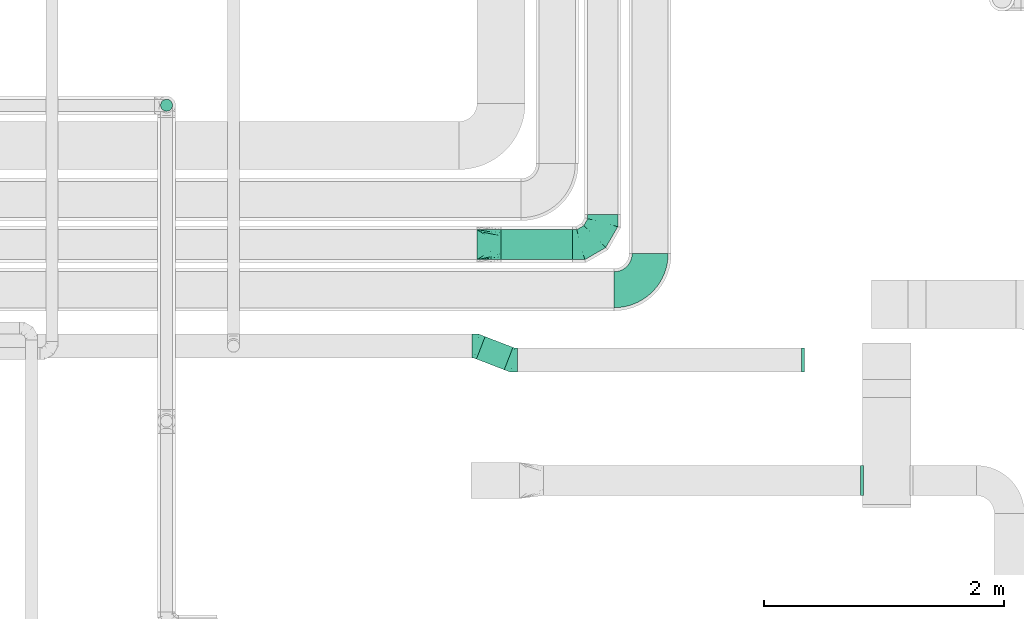
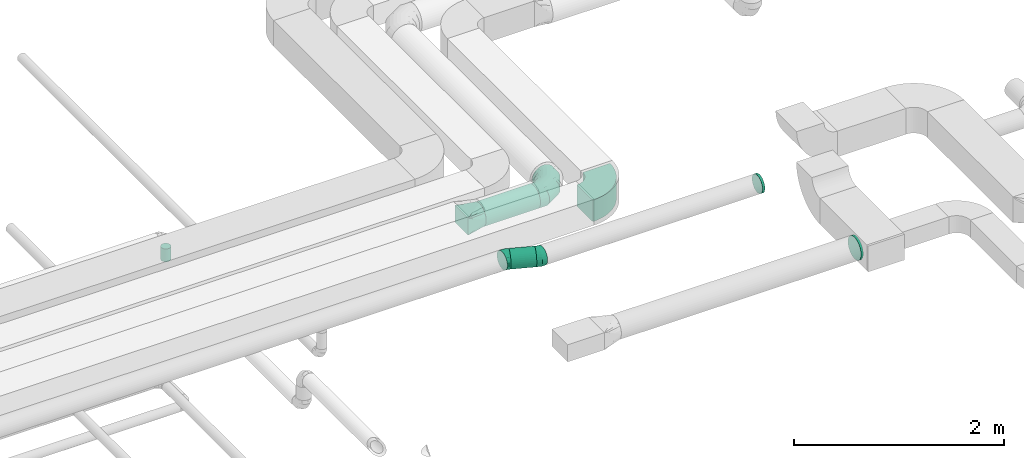
# One storey, part 43 of 92: 7 flow fittings, 3 flow segments.
"""IFC2X3 building model written with IfcOpenShell, lengths in millimetres."""

from ifc_helpers import new_model, entity, si_unit, converted_unit, derived_unit, direction, frame, frame_2d, origin, origin_2d_with_axis, place, context, subcontext, project, spatial, polyline, circle_curve, parameter, trimmed, segment, composite_curve, circle, outline, extrude, faceted_brep, source, transform, mapped, material, type_object, type_shapes, element, save


model = new_model("IFC2X3")

# Units and contexts
model_context = context("Model", 3, precision=0.01, world=origin(), true_north=direction((6.12303176911189e-17, 1.0)))
body_context = subcontext(model_context, "Body", "Model", "MODEL_VIEW")
ifc_project = project(units=[si_unit("LENGTHUNIT", "METRE", prefix="MILLI"), si_unit("AREAUNIT", "SQUARE_METRE"), si_unit("VOLUMEUNIT", "CUBIC_METRE"), converted_unit("PLANEANGLEUNIT", "DEGREE", entity("IfcRatioMeasure", 0.0174532925199433), si_unit("PLANEANGLEUNIT", "RADIAN"), dimensions=[0, 0, 0, 0, 0, 0, 0]), si_unit("MASSUNIT", "GRAM", prefix="KILO"), derived_unit("MASSDENSITYUNIT", [(si_unit("MASSUNIT", "GRAM", prefix="KILO"), 1), (si_unit("LENGTHUNIT", "METRE"), -3)]), derived_unit("MOMENTOFINERTIAUNIT", [(si_unit("LENGTHUNIT", "METRE"), 4)]), si_unit("TIMEUNIT", "SECOND"), si_unit("FREQUENCYUNIT", "HERTZ"), si_unit("THERMODYNAMICTEMPERATUREUNIT", "DEGREE_CELSIUS"), derived_unit("THERMALTRANSMITTANCEUNIT", [(si_unit("MASSUNIT", "GRAM", prefix="KILO"), 1), (si_unit("THERMODYNAMICTEMPERATUREUNIT", "KELVIN"), -1), (si_unit("TIMEUNIT", "SECOND"), -3)]), derived_unit("VOLUMETRICFLOWRATEUNIT", [(si_unit("LENGTHUNIT", "METRE"), 3), (si_unit("TIMEUNIT", "SECOND"), -1)]), derived_unit("MASSFLOWRATEUNIT", [(si_unit("MASSUNIT", "GRAM", prefix="KILO"), 1), (si_unit("TIMEUNIT", "SECOND"), -1)]), derived_unit("ROTATIONALFREQUENCYUNIT", [(si_unit("TIMEUNIT", "SECOND"), -1)]), si_unit("ELECTRICCURRENTUNIT", "AMPERE"), si_unit("ELECTRICVOLTAGEUNIT", "VOLT"), si_unit("POWERUNIT", "WATT"), si_unit("FORCEUNIT", "NEWTON", prefix="KILO"), si_unit("ILLUMINANCEUNIT", "LUX"), si_unit("LUMINOUSFLUXUNIT", "LUMEN"), si_unit("LUMINOUSINTENSITYUNIT", "CANDELA"), derived_unit("USERDEFINED", [(si_unit("MASSUNIT", "GRAM", prefix="KILO"), -1), (si_unit("LENGTHUNIT", "METRE"), -2), (si_unit("TIMEUNIT", "SECOND"), 3), (si_unit("LUMINOUSFLUXUNIT", "LUMEN"), 1)]), derived_unit("LINEARVELOCITYUNIT", [(si_unit("LENGTHUNIT", "METRE"), 1), (si_unit("TIMEUNIT", "SECOND"), -1)]), si_unit("PRESSUREUNIT", "PASCAL"), derived_unit("USERDEFINED", [(si_unit("LENGTHUNIT", "METRE"), -2), (si_unit("MASSUNIT", "GRAM", prefix="KILO"), 1), (si_unit("TIMEUNIT", "SECOND"), -2)]), derived_unit("LINEARFORCEUNIT", [(si_unit("MASSUNIT", "GRAM", prefix="KILO"), 1), (si_unit("LENGTHUNIT", "METRE"), 1), (si_unit("TIMEUNIT", "SECOND"), -2), (si_unit("LENGTHUNIT", "METRE"), -1)]), derived_unit("PLANARFORCEUNIT", [(si_unit("MASSUNIT", "GRAM", prefix="KILO"), 1), (si_unit("LENGTHUNIT", "METRE"), 1), (si_unit("TIMEUNIT", "SECOND"), -2), (si_unit("LENGTHUNIT", "METRE"), -2)])], contexts=[model_context])

# Site, building, storey
site_placement = place(None, origin())
site = spatial("IfcSite", under=ifc_project, at=site_placement, CompositionType="ELEMENT")
building_placement = place(site_placement, origin())
building = spatial("IfcBuilding", under=site, at=building_placement, CompositionType="ELEMENT")
storey_placement = place(building_placement, frame((0.0, 0.0, 4200.0)))
storey = spatial("IfcBuildingStorey", under=building, at=storey_placement, CompositionType="ELEMENT", Elevation=4200.0)

# Flow segments
duct_segment_type = type_object("IfcDuctSegmentType", PredefinedType="NOTDEFINED")
flow_segment_1_placement = place(storey_placement, frame((21724.05, 12068.05, 3173.4)))
element("IfcFlowSegment", 1, at=flow_segment_1_placement, inside=storey, type_object=duct_segment_type, context=body_context, shape_type="SweptSolid", body=[
    extrude(circle(Radius=125.0, at=origin_2d_with_axis()), frame((0.0, 126.6, 126.6), z_axis=(1.0, 0.0, 0.0), x_axis=(0.0, -1.0, 0.0)), (0.0, 0.0, 1.0), 596.921497590628),
])
flow_segment_2_placement = place(storey_placement, frame((18890.46, 13302.68, 3050.0)))
element("IfcFlowSegment", 2, at=flow_segment_2_placement, inside=storey, type_object=duct_segment_type, context=body_context, shape_type="SweptSolid", body=[
    extrude(circle(Radius=50.0, at=origin_2d_with_axis()), frame((51.6, 51.6, 0.0), z_axis=(0.0, 0.0, 1.0), x_axis=(0.0, 1.0, 0.0)), (0.0, 0.0, 1.0), 150.000000000007),
])
flow_segment_3_placement = place(storey_placement, frame((21518.46, 11152.26, 3258.4)))
element("IfcFlowSegment", 3, at=flow_segment_3_placement, inside=storey, type_object=duct_segment_type, context=body_context, shape_type="SweptSolid", body=[
    extrude(circle(Radius=100.0, at=origin_2d_with_axis()), frame((37.63, 184.28, 101.6), z_axis=(0.93280621162053, -0.360378372772499, 0.0), x_axis=(-0.360378372772499, -0.93280621162053, 0.0)), (0.0, 0.0, 1.0), 248.086941829669),
])

# Flow fittings
ifc_material = material()
duct_fitting_type_1 = type_object("IfcDuctFittingType", PredefinedType="NOTDEFINED", material=ifc_material)
shared_shape_1 = source(origin(), body_context, "Body", "Brep", [
    faceted_brep([(-250.0, 0.0, -125.0), (-250.0, -32.35, -120.74), (-250.0, -62.5, -108.25), (-250.0, -88.39, -88.39), (-250.0, -108.25, -62.5), (-250.0, -120.74, -32.35), (-250.0, -125.0, 0.0), (-250.0, -120.74, 32.35), (-250.0, -108.25, 62.5), (-250.0, -88.39, 88.39), (-250.0, -62.5, 108.25), (-250.0, -32.35, 120.74), (-250.0, 0.0, 125.0), (-250.0, 32.35, 120.74), (-250.0, 62.5, 108.25), (-250.0, 88.39, 88.39), (-250.0, 108.25, 62.5), (-250.0, 120.74, 32.35), (-250.0, 125.0, 0.0), (-250.0, 120.74, -32.35), (-250.0, 108.25, -62.5), (-250.0, 88.39, -88.39), (-250.0, 62.5, -108.25), (-250.0, 32.35, -120.74), (-191.68, 32.35, 120.74), (-199.76, 62.5, 108.25), (-183.01, 0.0, 125.0), (-206.7, 88.39, 88.39), (-215.37, 120.74, 32.35), (-216.51, 125.0, 0.0), (-212.02, 108.25, 62.5), (-212.02, 108.25, -62.5), (-206.7, 88.39, -88.39), (-215.37, 120.74, -32.35), (-191.68, 32.35, -120.74), (-183.01, 0.0, -125.0), (-199.76, 62.5, -108.25), (-174.34, -32.35, -120.74), (-166.27, -62.5, -108.25), (-159.33, -88.39, -88.39), (-154.01, -108.25, -62.5), (-150.66, -120.74, -32.35), (-149.52, -125.0, 0.0), (-150.66, -120.74, 32.35), (-154.01, -108.25, 62.5), (-159.33, -88.39, 88.39), (-166.27, -62.5, 108.25), (-174.34, -32.35, 120.74), (-90.67, 90.67, 120.74), (-112.74, 112.74, 108.25), (-66.99, 66.99, 125.0), (-131.69, 131.69, 88.39), (-146.23, 146.23, 62.5), (-155.38, 155.38, 32.35), (-158.49, 158.49, 0.0), (-155.38, 155.38, -32.35), (-146.23, 146.23, -62.5), (-131.69, 131.69, -88.39), (-90.67, 90.67, -120.74), (-66.99, 66.99, -125.0), (-112.74, 112.74, -108.25), (-43.3, 43.3, -120.74), (-21.23, 21.23, -108.25), (-2.28, 2.28, -88.39), (12.26, -12.26, -62.5), (21.4, -21.4, -32.35), (24.52, -24.52, 0.0), (21.4, -21.4, 32.35), (12.26, -12.26, 62.5), (-2.28, 2.28, 88.39), (-21.23, 21.23, 108.25), (-43.3, 43.3, 120.74), (-32.35, 191.68, 120.74), (-62.5, 199.76, 108.25), (0.0, 183.01, 125.0), (-88.39, 206.7, 88.39), (-108.25, 212.02, 62.5), (-120.74, 215.37, 32.35), (-125.0, 216.51, 0.0), (-120.74, 215.37, -32.35), (-108.25, 212.02, -62.5), (-88.39, 206.7, -88.39), (-32.35, 191.68, -120.74), (0.0, 183.01, -125.0), (-62.5, 199.76, -108.25), (32.35, 174.34, -120.74), (62.5, 166.27, -108.25), (88.39, 159.33, -88.39), (108.25, 154.01, -62.5), (120.74, 150.66, -32.35), (125.0, 149.52, 0.0), (120.74, 150.66, 32.35), (108.25, 154.01, 62.5), (88.39, 159.33, 88.39), (62.5, 166.27, 108.25), (32.35, 174.34, 120.74), (-32.35, 250.0, -120.74), (-62.5, 250.0, -108.25), (-88.39, 250.0, -88.39), (-108.25, 250.0, -62.5), (-120.74, 250.0, -32.35), (-125.0, 250.0, 0.0), (-120.74, 250.0, 32.35), (-108.25, 250.0, 62.5), (-88.39, 250.0, 88.39), (-62.5, 250.0, 108.25), (-32.35, 250.0, 120.74), (0.0, 250.0, 125.0), (32.35, 250.0, 120.74), (62.5, 250.0, 108.25), (88.39, 250.0, 88.39), (108.25, 250.0, 62.5), (120.74, 250.0, 32.35), (125.0, 250.0, 0.0), (120.74, 250.0, -32.35), (108.25, 250.0, -62.5), (88.39, 250.0, -88.39), (62.5, 250.0, -108.25), (32.35, 250.0, -120.74), (0.0, 250.0, -125.0)], [[[0, 1, 2, 3, 4, 5, 6, 7, 8, 9, 10, 11, 12, 13, 14, 15, 16, 17, 18, 19, 20, 21, 22, 23]], [[24, 25, 14, 13]], [[26, 24, 13, 12]], [[14, 25, 27, 15]], [[28, 29, 18, 17]], [[30, 28, 17, 16]], [[15, 27, 30, 16]], [[20, 31, 32, 21]], [[33, 31, 20, 19]], [[18, 29, 33, 19]], [[34, 35, 0, 23]], [[36, 34, 23, 22]], [[21, 32, 36, 22]], [[1, 0, 35, 37]], [[2, 1, 37, 38]], [[38, 39, 3, 2]], [[5, 4, 40, 41]], [[6, 5, 41, 42]], [[39, 40, 4, 3]], [[6, 42, 43, 7]], [[7, 43, 44, 8]], [[8, 44, 45, 9]], [[9, 45, 46, 10]], [[10, 46, 47, 11]], [[26, 12, 11, 47]], [[48, 49, 25, 24]], [[50, 48, 24, 26]], [[27, 25, 49, 51]], [[52, 53, 28, 30]], [[51, 52, 30, 27]], [[29, 28, 53, 54]], [[55, 56, 31, 33]], [[54, 55, 33, 29]], [[32, 31, 56, 57]], [[58, 59, 35, 34]], [[60, 58, 34, 36]], [[57, 60, 36, 32]], [[37, 35, 59, 61]], [[38, 37, 61, 62]], [[39, 38, 62, 63]], [[41, 40, 64, 65]], [[42, 41, 65, 66]], [[63, 64, 40, 39]], [[43, 42, 66, 67]], [[44, 43, 67, 68]], [[68, 69, 45, 44]], [[46, 45, 69, 70]], [[47, 46, 70, 71]], [[26, 47, 71, 50]], [[72, 73, 49, 48]], [[74, 72, 48, 50]], [[51, 49, 73, 75]], [[76, 77, 53, 52]], [[75, 76, 52, 51]], [[54, 53, 77, 78]], [[79, 80, 56, 55]], [[78, 79, 55, 54]], [[57, 56, 80, 81]], [[82, 83, 59, 58]], [[84, 82, 58, 60]], [[81, 84, 60, 57]], [[61, 59, 83, 85]], [[62, 61, 85, 86]], [[63, 62, 86, 87]], [[65, 64, 88, 89]], [[66, 65, 89, 90]], [[87, 88, 64, 63]], [[67, 66, 90, 91]], [[68, 67, 91, 92]], [[92, 93, 69, 68]], [[70, 69, 93, 94]], [[71, 70, 94, 95]], [[50, 71, 95, 74]], [[96, 97, 98, 99, 100, 101, 102, 103, 104, 105, 106, 107, 108, 109, 110, 111, 112, 113, 114, 115, 116, 117, 118, 119]], [[72, 74, 107, 106]], [[73, 72, 106, 105]], [[75, 73, 105, 104]], [[77, 76, 103, 102]], [[78, 77, 102, 101]], [[75, 104, 103, 76]], [[78, 101, 100, 79]], [[79, 100, 99, 80]], [[80, 99, 98, 81]], [[84, 97, 96, 82]], [[82, 96, 119, 83]], [[84, 81, 98, 97]], [[83, 119, 118, 85]], [[85, 118, 117, 86]], [[116, 87, 86, 117]], [[88, 115, 114, 89]], [[89, 114, 113, 90]], [[115, 88, 87, 116]], [[91, 90, 113, 112]], [[92, 91, 112, 111]], [[111, 110, 93, 92]], [[95, 94, 109, 108]], [[74, 95, 108, 107]], [[110, 109, 94, 93]]]),
])
type_shapes(duct_fitting_type_1, [shared_shape_1])
flow_fitting_1_placement = place(storey_placement, frame((22570.98, 12194.64, 3300.0)))
element("IfcFlowFitting", 4, at=flow_fitting_1_placement, inside=storey, type_object=duct_fitting_type_1, material=ifc_material, context=body_context, shape_type="MappedRepresentation", body=[
    mapped(shared_shape_1, transform((0.0, 0.0, 0.0), scale=1.0)),
])
duct_fitting_type_2 = type_object("IfcDuctFittingType", PredefinedType="NOTDEFINED", material=ifc_material)
shared_shape_2 = source(origin(), body_context, "Body", "Brep", [
    faceted_brep([(20.0, 32.35, -120.74), (20.0, 62.5, -108.25), (20.0, 88.39, -88.39), (20.0, 108.25, -62.5), (20.0, 120.74, -32.35), (20.0, 125.0, 0.0), (20.0, 120.74, 32.35), (20.0, 108.25, 62.5), (20.0, 88.39, 88.39), (20.0, 62.5, 108.25), (20.0, 32.35, 120.74), (20.0, 0.0, 125.0), (20.0, -32.35, 120.74), (20.0, -62.5, 108.25), (20.0, -88.39, 88.39), (20.0, -108.25, 62.5), (20.0, -120.74, 32.35), (20.0, -125.0, 0.0), (20.0, -120.74, -32.35), (20.0, -108.25, -62.5), (20.0, -88.39, -88.39), (20.0, -62.5, -108.25), (20.0, -32.35, -120.74), (20.0, 0.0, -125.0), (0.0, 0.0, 125.0), (0.0, 32.35, 120.74), (-6.1, 32.35, 120.74), (-6.1, 0.0, 125.0), (0.0, 62.5, 108.25), (-6.1, 62.5, 108.25), (0.0, 88.39, 88.39), (-6.1, 88.39, 88.39), (0.0, 108.25, 62.5), (0.0, 120.74, 32.35), (-6.1, 120.74, 32.35), (-6.1, 108.25, 62.5), (0.0, 125.0, 0.0), (-6.1, 125.0, 0.0), (0.0, 120.74, -32.35), (-6.1, 120.74, -32.35), (0.0, 108.25, -62.5), (-6.1, 108.25, -62.5), (0.0, 88.39, -88.39), (-6.1, 88.39, -88.39), (0.0, 62.5, -108.25), (0.0, 32.35, -120.74), (-6.1, 32.35, -120.74), (-6.1, 62.5, -108.25), (0.0, 0.0, -125.0), (-6.1, 0.0, -125.0), (0.0, -32.35, -120.74), (-6.1, -32.35, -120.74), (0.0, -62.5, -108.25), (-6.1, -62.5, -108.25), (0.0, -88.39, -88.39), (-6.1, -88.39, -88.39), (0.0, -108.25, -62.5), (0.0, -120.74, -32.35), (-6.1, -120.74, -32.35), (-6.1, -108.25, -62.5), (0.0, -125.0, 0.0), (-6.1, -125.0, 0.0), (0.0, -120.74, 32.35), (-6.1, -120.74, 32.35), (0.0, -108.25, 62.5), (-6.1, -108.25, 62.5), (0.0, -88.39, 88.39), (-6.1, -88.39, 88.39), (0.0, -62.5, 108.25), (0.0, -32.35, 120.74), (-6.1, -32.35, 120.74), (-6.1, -62.5, 108.25)], [[[0, 1, 2, 3, 4, 5, 6, 7, 8, 9, 10, 11, 12, 13, 14, 15, 16, 17, 18, 19, 20, 21, 22, 23]], [[24, 11, 10, 25, 26, 27]], [[25, 10, 9, 28, 29, 26]], [[28, 9, 8, 30, 31, 29]], [[32, 7, 6, 33, 34, 35]], [[33, 6, 5, 36, 37, 34]], [[30, 8, 7, 32, 35, 31]], [[36, 5, 4, 38, 39, 37]], [[38, 4, 3, 40, 41, 39]], [[40, 3, 2, 42, 43, 41]], [[44, 1, 0, 45, 46, 47]], [[45, 0, 23, 48, 49, 46]], [[42, 2, 1, 44, 47, 43]], [[48, 23, 22, 50, 51, 49]], [[50, 22, 21, 52, 53, 51]], [[52, 21, 20, 54, 55, 53]], [[56, 19, 18, 57, 58, 59]], [[57, 18, 17, 60, 61, 58]], [[54, 20, 19, 56, 59, 55]], [[60, 17, 16, 62, 63, 61]], [[62, 16, 15, 64, 65, 63]], [[64, 15, 14, 66, 67, 65]], [[68, 13, 12, 69, 70, 71]], [[69, 12, 11, 24, 27, 70]], [[66, 14, 13, 68, 71, 67]], [[49, 51, 53, 55, 59, 58, 61, 63, 65, 67, 71, 70, 27, 26, 29, 31, 35, 34, 37, 39, 41, 43, 47, 46]]]),
])
type_shapes(duct_fitting_type_2, [shared_shape_2])
flow_fitting_2_placement = place(storey_placement, frame((24733.23, 10232.66, 3050.0), z_axis=(0.0, 0.0, -1.0), x_axis=(-1.0, 0.0, 0.0)))
element("IfcFlowFitting", 5, at=flow_fitting_2_placement, inside=storey, type_object=duct_fitting_type_2, material=ifc_material, context=body_context, shape_type="MappedRepresentation", body=[
    mapped(shared_shape_2, transform((0.0, 0.0, 0.0), scale=1.0)),
])
duct_fitting_type_3 = type_object("IfcDuctFittingType", PredefinedType="NOTDEFINED", material=ifc_material)
shared_shape_3 = source(origin(), body_context, "Body", "Brep", [
    faceted_brep([(20.0, 25.88, -96.59), (20.0, 50.0, -86.6), (20.0, 70.71, -70.71), (20.0, 86.6, -50.0), (20.0, 96.59, -25.88), (20.0, 100.0, 0.0), (20.0, 96.59, 25.88), (20.0, 86.6, 50.0), (20.0, 70.71, 70.71), (20.0, 50.0, 86.6), (20.0, 25.88, 96.59), (20.0, 0.0, 100.0), (20.0, -25.88, 96.59), (20.0, -50.0, 86.6), (20.0, -70.71, 70.71), (20.0, -86.6, 50.0), (20.0, -96.59, 25.88), (20.0, -100.0, 0.0), (20.0, -96.59, -25.88), (20.0, -86.6, -50.0), (20.0, -70.71, -70.71), (20.0, -50.0, -86.6), (20.0, -25.88, -96.59), (20.0, 0.0, -100.0), (0.0, 0.0, 100.0), (0.0, 25.88, 96.59), (-6.1, 25.88, 96.59), (-6.1, 0.0, 100.0), (0.0, 50.0, 86.6), (-6.1, 50.0, 86.6), (0.0, 70.71, 70.71), (-6.1, 70.71, 70.71), (0.0, 86.6, 50.0), (0.0, 96.59, 25.88), (-6.1, 96.59, 25.88), (-6.1, 86.6, 50.0), (0.0, 100.0, 0.0), (-6.1, 100.0, 0.0), (0.0, 96.59, -25.88), (-6.1, 96.59, -25.88), (0.0, 86.6, -50.0), (-6.1, 86.6, -50.0), (0.0, 70.71, -70.71), (-6.1, 70.71, -70.71), (0.0, 50.0, -86.6), (0.0, 25.88, -96.59), (-6.1, 25.88, -96.59), (-6.1, 50.0, -86.6), (0.0, 0.0, -100.0), (-6.1, 0.0, -100.0), (0.0, -25.88, -96.59), (-6.1, -25.88, -96.59), (0.0, -50.0, -86.6), (-6.1, -50.0, -86.6), (0.0, -70.71, -70.71), (-6.1, -70.71, -70.71), (0.0, -86.6, -50.0), (0.0, -96.59, -25.88), (-6.1, -96.59, -25.88), (-6.1, -86.6, -50.0), (0.0, -100.0, 0.0), (-6.1, -100.0, 0.0), (0.0, -96.59, 25.88), (-6.1, -96.59, 25.88), (0.0, -86.6, 50.0), (-6.1, -86.6, 50.0), (0.0, -70.71, 70.71), (-6.1, -70.71, 70.71), (0.0, -50.0, 86.6), (0.0, -25.88, 96.59), (-6.1, -25.88, 96.59), (-6.1, -50.0, 86.6)], [[[0, 1, 2, 3, 4, 5, 6, 7, 8, 9, 10, 11, 12, 13, 14, 15, 16, 17, 18, 19, 20, 21, 22, 23]], [[24, 11, 10, 25, 26, 27]], [[25, 10, 9, 28, 29, 26]], [[28, 9, 8, 30, 31, 29]], [[32, 7, 6, 33, 34, 35]], [[33, 6, 5, 36, 37, 34]], [[30, 8, 7, 32, 35, 31]], [[36, 5, 4, 38, 39, 37]], [[38, 4, 3, 40, 41, 39]], [[40, 3, 2, 42, 43, 41]], [[44, 1, 0, 45, 46, 47]], [[45, 0, 23, 48, 49, 46]], [[42, 2, 1, 44, 47, 43]], [[48, 23, 22, 50, 51, 49]], [[50, 22, 21, 52, 53, 51]], [[52, 21, 20, 54, 55, 53]], [[56, 19, 18, 57, 58, 59]], [[57, 18, 17, 60, 61, 58]], [[54, 20, 19, 56, 59, 55]], [[60, 17, 16, 62, 63, 61]], [[62, 16, 15, 64, 65, 63]], [[64, 15, 14, 66, 67, 65]], [[68, 13, 12, 69, 70, 71]], [[69, 12, 11, 24, 27, 70]], [[66, 14, 13, 68, 71, 67]], [[49, 51, 53, 55, 59, 58, 61, 63, 65, 67, 71, 70, 27, 26, 29, 31, 35, 34, 37, 39, 41, 43, 47, 46]]]),
])
type_shapes(duct_fitting_type_3, [shared_shape_3])
flow_fitting_3_placement = place(storey_placement, frame((24242.3, 11233.69, 3360.0), z_axis=(0.0, 1.0, 0.0), x_axis=(-1.0, 0.0, 0.0)))
element("IfcFlowFitting", 6, at=flow_fitting_3_placement, inside=storey, type_object=duct_fitting_type_3, material=ifc_material, context=body_context, shape_type="MappedRepresentation", body=[
    mapped(shared_shape_3, transform((0.0, 0.0, 0.0), scale=1.0)),
])
duct_fitting_type_4 = type_object("IfcDuctFittingType", PredefinedType="NOTDEFINED", material=ifc_material)
shared_shape_4 = source(origin(), body_context, "Body", "Brep", [
    faceted_brep([(200.0, 73.47, 101.13), (200.0, 56.05, 110.0), (200.0, 38.63, 118.88), (200.0, 23.84, 121.22), (200.0, 11.92, 123.11), (200.0, 5.96, 124.06), (200.0, 0.0, 125.0), (200.0, -5.96, 124.06), (200.0, -11.92, 123.11), (200.0, -23.84, 121.22), (200.0, -38.63, 118.88), (200.0, -56.05, 110.0), (200.0, -73.47, 101.13), (200.0, -87.3, 87.3), (200.0, -101.13, 73.47), (200.0, -110.0, 56.05), (200.0, -118.88, 38.63), (200.0, -121.22, 23.84), (200.0, -123.11, 11.92), (200.0, -124.06, 5.96), (200.0, -125.0, 0.0), (200.0, -124.06, -5.96), (200.0, -123.11, -11.92), (200.0, -121.22, -23.84), (200.0, -118.88, -38.63), (200.0, -110.0, -56.05), (200.0, -101.13, -73.47), (200.0, -87.3, -87.3), (200.0, -73.47, -101.13), (200.0, -56.05, -110.0), (200.0, -38.63, -118.88), (200.0, -23.84, -121.22), (200.0, -11.92, -123.11), (200.0, -5.96, -124.06), (200.0, 0.0, -125.0), (200.0, 5.96, -124.06), (200.0, 11.92, -123.11), (200.0, 23.84, -121.22), (200.0, 38.63, -118.88), (200.0, 56.05, -110.0), (200.0, 73.47, -101.13), (200.0, 87.3, -87.3), (200.0, 101.13, -73.47), (200.0, 110.0, -56.05), (200.0, 118.88, -38.63), (200.0, 121.22, -23.84), (200.0, 123.11, -11.92), (200.0, 124.06, -5.96), (200.0, 125.0, 0.0), (200.0, 124.06, 5.96), (200.0, 123.11, 11.92), (200.0, 121.22, 23.84), (200.0, 118.88, 38.63), (200.0, 110.0, 56.05), (200.0, 101.13, 73.47), (200.0, 87.3, 87.3), (0.0, -125.0, 100.0), (0.0, 125.0, 100.0), (0.0, 125.0, -100.0), (0.0, -125.0, -100.0), (104.11, -59.93, 113.01), (100.0, -103.94, 96.79), (26.03, -108.73, 103.25), (78.09, -76.2, 109.76), (52.06, -92.46, 106.51), (188.01, -7.49, 123.5), (176.03, -14.98, 122.0), (152.06, -29.96, 119.01), (128.09, -44.95, 116.01), (52.06, -125.0, 73.97), (78.09, -125.0, 60.96), (104.11, -125.0, 47.94), (128.09, -125.0, 35.96), (152.06, -125.0, 23.97), (176.03, -125.0, 11.99), (188.01, -125.0, 5.99), (26.03, -125.0, 86.99), (26.03, -125.0, -86.99), (52.06, -125.0, -73.97), (78.09, -125.0, -60.96), (104.11, -125.0, -47.94), (128.09, -125.0, -35.96), (152.06, -125.0, -23.97), (176.03, -125.0, -11.99), (188.01, -125.0, -5.99), (100.0, -109.29, -91.44), (52.06, -92.46, -106.51), (78.09, -76.2, -109.76), (104.11, -59.93, -113.01), (128.09, -44.95, -116.01), (152.06, -29.96, -119.01), (176.03, -14.98, -122.0), (188.01, -7.49, -123.5), (26.03, -108.73, -103.25), (26.03, 108.73, -103.25), (52.06, 92.46, -106.51), (78.09, 76.2, -109.76), (104.11, 59.93, -113.01), (128.09, 44.95, -116.01), (152.06, 29.96, -119.01), (176.03, 14.98, -122.0), (188.01, 7.49, -123.5), (100.0, 103.94, -96.79), (52.06, 125.0, -73.97), (78.09, 125.0, -60.96), (104.11, 125.0, -47.94), (128.09, 125.0, -35.96), (152.06, 125.0, -23.97), (176.03, 125.0, -11.99), (188.01, 125.0, -5.99), (26.03, 125.0, -86.99), (26.03, 125.0, 86.99), (52.06, 125.0, 73.97), (78.09, 125.0, 60.96), (104.11, 125.0, 47.94), (128.09, 125.0, 35.96), (152.06, 125.0, 23.97), (176.03, 125.0, 11.99), (188.01, 125.0, 5.99), (100.0, 109.29, 91.44), (52.06, 92.46, 106.51), (78.09, 76.2, 109.76), (104.11, 59.93, 113.01), (128.09, 44.95, 116.01), (152.06, 29.96, 119.01), (176.03, 14.98, 122.0), (188.01, 7.49, 123.5), (26.03, 108.73, 103.25)], [[[0, 1, 2, 3, 4, 5, 6, 7, 8, 9, 10, 11, 12, 13, 14, 15, 16, 17, 18, 19, 20, 21, 22, 23, 24, 25, 26, 27, 28, 29, 30, 31, 32, 33, 34, 35, 36, 37, 38, 39, 40, 41, 42, 43, 44, 45, 46, 47, 48, 49, 50, 51, 52, 53, 54, 55]], [[56, 57, 58, 59]], [[60, 11, 10]], [[56, 61, 62]], [[11, 60, 63, 64]], [[65, 66, 67, 68, 60, 10, 9, 8, 7, 6]], [[62, 61, 12]], [[15, 69, 70, 71]], [[64, 12, 11]], [[16, 71, 72, 73, 74, 75, 20, 19, 18, 17]], [[14, 76, 69]], [[71, 16, 15]], [[61, 76, 13]], [[12, 64, 62]], [[76, 14, 13]], [[12, 61, 13]], [[61, 56, 76]], [[69, 15, 14]], [[75, 74, 73, 72, 71, 70, 69, 76, 56, 59, 77, 78, 79, 80, 81, 82, 83, 84, 20]], [[80, 25, 24]], [[59, 85, 77]], [[25, 80, 79, 78]], [[84, 83, 82, 81, 80, 24, 23, 22, 21, 20]], [[77, 85, 26]], [[29, 86, 87, 88]], [[78, 26, 25]], [[30, 88, 89, 90, 91, 92, 34, 33, 32, 31]], [[28, 93, 86]], [[88, 30, 29]], [[85, 93, 27]], [[26, 78, 77]], [[93, 28, 27]], [[26, 85, 27]], [[85, 59, 93]], [[86, 29, 28]], [[92, 91, 90, 89, 88, 87, 86, 93, 59, 58, 94, 95, 96, 97, 98, 99, 100, 101, 34]], [[97, 39, 38]], [[58, 102, 94]], [[39, 97, 96, 95]], [[101, 100, 99, 98, 97, 38, 37, 36, 35, 34]], [[94, 102, 40]], [[43, 103, 104, 105]], [[95, 40, 39]], [[44, 105, 106, 107, 108, 109, 48, 47, 46, 45]], [[42, 110, 103]], [[105, 44, 43]], [[102, 110, 41]], [[40, 95, 94]], [[110, 42, 41]], [[40, 102, 41]], [[102, 58, 110]], [[103, 43, 42]], [[58, 57, 111, 112, 113, 114, 115, 116, 117, 118, 48, 109, 108, 107, 106, 105, 104, 103, 110]], [[114, 53, 52]], [[57, 119, 111]], [[53, 114, 113, 112]], [[118, 117, 116, 115, 114, 52, 51, 50, 49, 48]], [[111, 119, 54]], [[1, 120, 121, 122]], [[112, 54, 53]], [[2, 122, 123, 124, 125, 126, 6, 5, 4, 3]], [[0, 127, 120]], [[122, 2, 1]], [[119, 127, 55]], [[54, 112, 111]], [[127, 0, 55]], [[54, 119, 55]], [[119, 57, 127]], [[120, 1, 0]], [[57, 56, 62, 64, 63, 60, 68, 67, 66, 65, 6, 126, 125, 124, 123, 122, 121, 120, 127]]]),
])
type_shapes(duct_fitting_type_4, [shared_shape_4])
flow_fitting_4_placement = place(storey_placement, frame((21524.05, 12194.64, 3300.0)))
element("IfcFlowFitting", 7, at=flow_fitting_4_placement, inside=storey, type_object=duct_fitting_type_4, material=ifc_material, context=body_context, shape_type="MappedRepresentation", body=[
    mapped(shared_shape_4, transform((0.0, 0.0, 0.0), scale=1.0)),
])
duct_fitting_type_5 = type_object("IfcDuctFittingType", PredefinedType="NOTDEFINED", material=ifc_material)
shared_shape_5 = source(origin(), body_context, "Body", "Brep", [
    faceted_brep([(-37.29, 0.0, -100.0), (-37.29, -25.88, -96.59), (-37.29, -50.0, -86.6), (-37.29, -70.71, -70.71), (-37.29, -86.6, -50.0), (-37.29, -96.59, -25.88), (-37.29, -100.0, 0.0), (-37.29, -96.59, 25.88), (-37.29, -86.6, 50.0), (-37.29, -70.71, 70.71), (-37.29, -50.0, 86.6), (-37.29, -25.88, 96.59), (-37.29, 0.0, 100.0), (-37.29, 25.88, 96.59), (-37.29, 50.0, 86.6), (-37.29, 70.71, 70.71), (-37.29, 86.6, 50.0), (-37.29, 96.59, 25.88), (-37.29, 100.0, 0.0), (-37.29, 96.59, -25.88), (-37.29, 86.6, -50.0), (-37.29, 70.71, -70.71), (-37.29, 50.0, -86.6), (-37.29, 25.88, -96.59), (-4.83, 25.88, 96.59), (-9.32, 50.0, 86.6), (0.0, 0.0, 100.0), (-13.18, 70.71, 70.71), (-18.01, 96.59, 25.88), (-18.65, 100.0, 0.0), (-16.15, 86.6, 50.0), (-16.15, 86.6, -50.0), (-13.18, 70.71, -70.71), (-18.01, 96.59, -25.88), (-4.83, 25.88, -96.59), (0.0, 0.0, -100.0), (-9.32, 50.0, -86.6), (4.83, -25.88, -96.59), (9.32, -50.0, -86.6), (13.18, -70.71, -70.71), (16.15, -86.6, -50.0), (18.01, -96.59, -25.88), (18.65, -100.0, 0.0), (18.01, -96.59, 25.88), (16.15, -86.6, 50.0), (13.18, -70.71, 70.71), (9.32, -50.0, 86.6), (4.83, -25.88, 96.59), (34.78, 13.44, 100.0), (25.46, 37.58, 96.59), (16.77, 60.08, 86.6), (9.3, 79.4, 70.71), (3.58, 94.22, 50.0), (-0.02, 103.54, 25.88), (-1.25, 106.72, 0.0), (-0.02, 103.54, -25.88), (3.58, 94.22, -50.0), (9.3, 79.4, -70.71), (16.77, 60.08, -86.6), (25.46, 37.58, -96.59), (34.78, 13.44, -100.0), (44.11, -10.7, -96.59), (52.8, -33.2, -86.6), (60.27, -52.52, -70.71), (65.99, -67.34, -50.0), (69.59, -76.66, -25.88), (70.82, -79.84, 0.0), (69.59, -76.66, 25.88), (65.99, -67.34, 50.0), (60.27, -52.52, 70.71), (44.11, -10.7, 96.59), (52.8, -33.2, 86.6)], [[[0, 1, 2, 3, 4, 5, 6, 7, 8, 9, 10, 11, 12, 13, 14, 15, 16, 17, 18, 19, 20, 21, 22, 23]], [[24, 25, 14, 13]], [[26, 24, 13, 12]], [[14, 25, 27, 15]], [[28, 29, 18, 17]], [[30, 28, 17, 16]], [[15, 27, 30, 16]], [[20, 31, 32, 21]], [[33, 31, 20, 19]], [[18, 29, 33, 19]], [[34, 35, 0, 23]], [[36, 34, 23, 22]], [[32, 36, 22, 21]], [[2, 1, 37, 38]], [[3, 2, 38, 39]], [[0, 35, 37, 1]], [[5, 4, 40, 41]], [[6, 5, 41, 42]], [[3, 39, 40, 4]], [[6, 42, 43, 7]], [[7, 43, 44, 8]], [[8, 44, 45, 9]], [[10, 46, 47, 11]], [[11, 47, 26, 12]], [[10, 9, 45, 46]], [[24, 26, 48, 49]], [[25, 24, 49, 50]], [[27, 25, 50, 51]], [[28, 30, 52, 53]], [[29, 28, 53, 54]], [[27, 51, 52, 30]], [[29, 54, 55, 33]], [[33, 55, 56, 31]], [[31, 56, 57, 32]], [[36, 58, 59, 34]], [[34, 59, 60, 35]], [[36, 32, 57, 58]], [[35, 60, 61, 37]], [[37, 61, 62, 38]], [[38, 62, 63, 39]], [[40, 64, 65, 41]], [[41, 65, 66, 42]], [[39, 63, 64, 40]], [[43, 42, 66, 67]], [[44, 43, 67, 68]], [[45, 44, 68, 69]], [[70, 48, 26, 47]], [[71, 70, 47, 46]], [[69, 71, 46, 45]], [[59, 58, 57, 56, 55, 54, 53, 52, 51, 50, 49, 48, 70, 71, 69, 68, 67, 66, 65, 64, 63, 62, 61, 60]]]),
])
type_shapes(duct_fitting_type_5, [shared_shape_5])
for number, where, z_axis, x_axis in (
    (8, (21521.31, 11349.98, 3360.0), (0.0, 3.30144791686109e-07, 1.0), (-0.932806211620542, 0.360378372772449, -1.18977042807145e-07)),
    (9, (21822.3, 11233.69, 3360.0), (0.0, -4.96250285089737e-08, 1.0), (0.93280621162053, -0.360378372772499, -1.78837870228528e-08)),
):
    element("IfcFlowFitting", number, at=place(storey_placement, frame(where, z_axis=z_axis, x_axis=x_axis)), inside=storey, type_object=duct_fitting_type_5, material=ifc_material, context=body_context, shape_type="MappedRepresentation", body=[
        mapped(shared_shape_5, transform((0.0, 0.0, 0.0), scale=1.0)),
    ])
duct_fitting_type_6 = type_object("IfcDuctFittingType", PredefinedType="NOTDEFINED", material=ifc_material)
shared_shape_6 = source(origin(), body_context, "Body", "SweptSolid", [
    extrude(outline(composite_curve([segment(polyline([(-300.0, -150.0), (0.0, -150.0)]), True, "CONTINUOUS"), segment(trimmed(circle_curve(frame_2d((150.0, -150.0), x_axis=(0.0, 1.0)), 150.0), [parameter(0.0)], [parameter(90.0)], True, "PARAMETER"), False, "CONTINUOUS"), segment(polyline([(150.0, 0.0), (150.0, 300.0)]), True, "CONTINUOUS"), segment(trimmed(circle_curve(frame_2d((150.0, -150.0), x_axis=(0.0, 1.0)), 450.0), [parameter(0.0)], [parameter(90.0000000000001)], True, "PARAMETER"), True, "CONTINUOUS")], self_intersect=False)), frame((-150.0, 150.0, -125.0), z_axis=(0.0, 0.0, 1.0), x_axis=(-1.0, 0.0, 0.0)), (0.0, 0.0, 1.0), 250.0),
])
type_shapes(duct_fitting_type_6, [shared_shape_6])
flow_fitting_5_placement = place(storey_placement, frame((22965.08, 11819.68, 3325.0)))
element("IfcFlowFitting", 10, at=flow_fitting_5_placement, inside=storey, type_object=duct_fitting_type_6, material=ifc_material, context=body_context, shape_type="MappedRepresentation", body=[
    mapped(shared_shape_6, transform((0.0, 0.0, 0.0), scale=1.0)),
])

save(model, "model.ifc")
